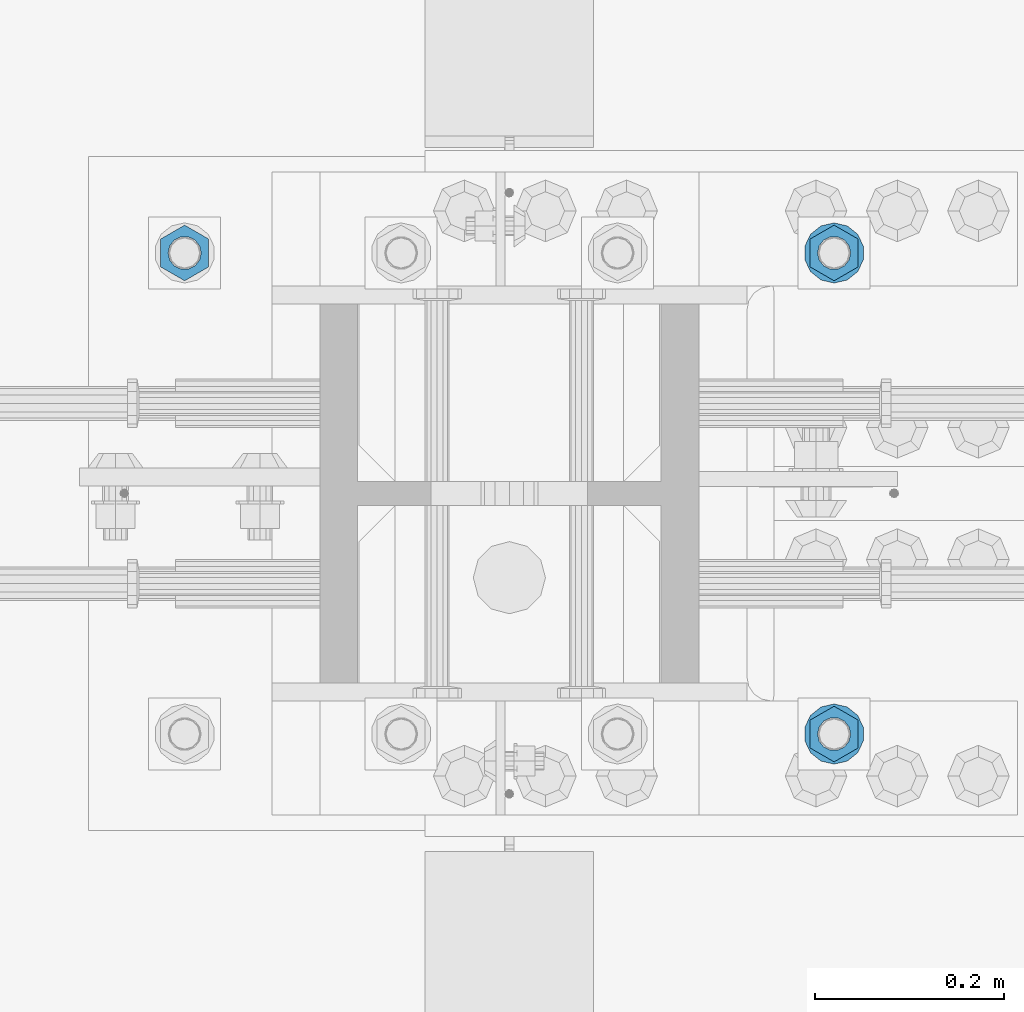
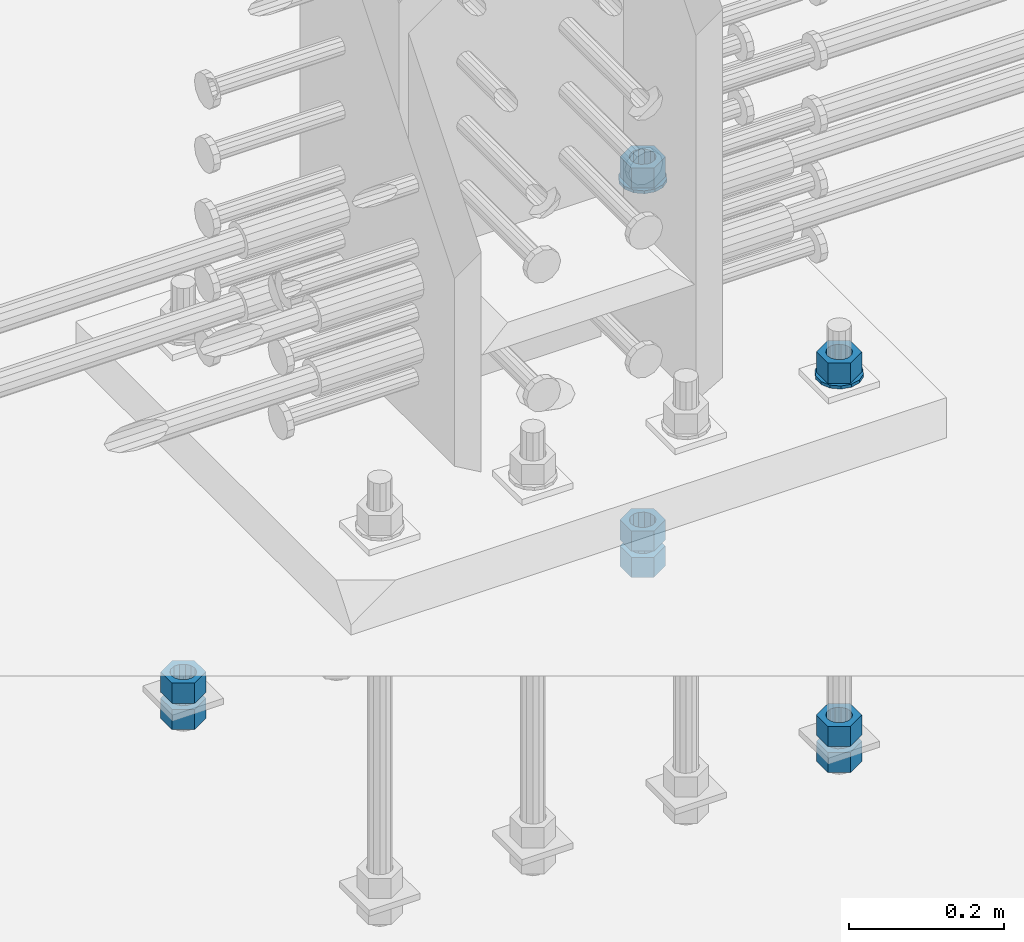
# One storey, part 993 of 1763: 10 columns, 1 element without a shape of its own.
"""IFC2X3 building model written with IfcOpenShell, lengths in millimetres."""

from ifc_helpers import new_model, si_unit, frame, origin_with_axes, place, context, subcontext, project, spatial, faceted_brep, material, type_object, element, aggregate, save


model = new_model("IFC2X3")

# Units and contexts
model_context = context("Model", 3, precision=1e-05, world=origin_with_axes())
body_context = subcontext(model_context, "Body", "Model", "MODEL_VIEW")
ifc_project = project(units=[si_unit("LENGTHUNIT", "METRE", prefix="MILLI"), si_unit("AREAUNIT", "SQUARE_METRE"), si_unit("VOLUMEUNIT", "CUBIC_METRE"), si_unit("MASSUNIT", "GRAM", prefix="KILO"), si_unit("TIMEUNIT", "SECOND"), si_unit("PLANEANGLEUNIT", "RADIAN"), si_unit("SOLIDANGLEUNIT", "STERADIAN"), si_unit("THERMODYNAMICTEMPERATUREUNIT", "DEGREE_CELSIUS"), si_unit("LUMINOUSINTENSITYUNIT", "LUMEN")], contexts=[model_context])

# Site, building, storey
site_placement = place(None, origin_with_axes())
site = spatial("IfcSite", under=ifc_project, at=site_placement, CompositionType="ELEMENT")
building_placement = place(site_placement, origin_with_axes())
building = spatial("IfcBuilding", under=site, at=building_placement, Name="Undefined", CompositionType="ELEMENT")
storey_placement = place(building_placement, origin_with_axes())
storey = spatial("IfcBuildingStorey", under=building, at=storey_placement, Name="Undefined", CompositionType="ELEMENT", Elevation=0.0)

# Assembly, columns
assembly_placement = place(storey_placement, origin_with_axes())
assembly = element("IfcElementAssembly", 1, at=assembly_placement, inside=storey, Name="TEMPLATE", AssemblyPlace="NOTDEFINED", PredefinedType="RIGID_FRAME")
ifc_material_1 = material(Name="STEEL/A563")
column_type_1 = type_object("IfcColumnType", Name="1-1/4_HEAVY_HEX_NUT", PredefinedType="NOTDEFINED")
column_1_placement = place(assembly_placement, frame((-72148.1372736972, 203.200000000843, 3957.6375), z_axis=(1.0, 0.0, 0.0), x_axis=(0.0, 0.0, -1.0)))
column_1 = element("IfcColumn", 2, at=column_1_placement, type_object=column_type_1, material=ifc_material_1, Name="NUT", ObjectType="1-1/4_HEAVY_HEX_NUT", context=body_context, shape_type="Brep", body=[
    faceted_brep([(0.0, -29.3700008392334, 0.0), (0.0, -14.6800003051758, -25.4300003051758), (31.75, -14.6800003051758, -25.4300003051758), (31.75, -29.3700008392334, 0.0), (0.0, 14.6800003051758, -25.4300003051758), (31.75, 14.6800003051758, -25.4300003051758), (0.0, 29.3700008392334, 0.0), (31.75, 29.3700008392334, 0.0), (0.0, 14.6800003051758, 25.4300003051758), (31.75, 14.6800003051758, 25.4300003051758), (0.0, -14.6800003051758, 25.4300003051758), (31.75, -14.6800003051758, 25.4300003051758), (0.0, 0.0, 17.4599990844727), (0.0, 7.57560968776022, 15.730915608714), (31.75, 7.57560968775942, 15.7309156087145), (31.75, 0.0, 17.4599990844727), (0.0, 13.6507769681037, 10.8861313696252), (31.75, 13.6507769681048, 10.8861313696314), (0.0, 17.0222404541215, 3.88521530314756), (31.75, 17.02224045412, 3.88521530315316), (0.0, 17.0222404541215, -3.88521530314756), (31.75, 17.02224045412, -3.88521530315332), (0.0, 13.6507769681037, -10.8861313696252), (31.75, 13.6507769681048, -10.8861313696316), (0.0, 7.57560968776022, -15.730915608714), (31.75, 7.57560968775942, -15.7309156087146), (0.0, 0.0, -17.4599990844727), (31.75, 0.0, -17.4599990844727), (0.0, -7.57560968776022, -15.730915608714), (31.75, -7.57560968775942, -15.7309156087145), (0.0, -13.6507769681037, -10.8861313696252), (31.75, -13.6507769681048, -10.8861313696314), (0.0, -17.0222404541215, -3.88521530314756), (31.75, -17.02224045412, -3.88521530315316), (0.0, -17.0222404541215, 3.88521530314756), (31.75, -17.02224045412, 3.88521530315332), (0.0, -13.6507769681037, 10.8861313696252), (31.75, -13.6507769681048, 10.8861313696316), (0.0, -7.57560968776022, 15.730915608714), (31.75, -7.57560968775942, 15.7309156087146)], [[[0, 1, 2, 3]], [[1, 4, 5, 2]], [[4, 6, 7, 5]], [[6, 8, 9, 7]], [[8, 10, 11, 9]], [[10, 0, 3, 11]], [[12, 13, 14, 15]], [[13, 16, 17, 14]], [[16, 18, 19, 17]], [[18, 20, 21, 19]], [[20, 22, 23, 21]], [[22, 24, 25, 23]], [[24, 26, 27, 25]], [[26, 28, 29, 27]], [[28, 30, 31, 29]], [[30, 32, 33, 31]], [[32, 34, 35, 33]], [[34, 36, 37, 35]], [[36, 38, 39, 37]], [[38, 12, 15, 39]], [[5, 7, 9, 11, 3, 2], [17, 19, 21, 23, 25, 27, 29, 31, 33, 35, 37, 39, 15, 14]], [[10, 8, 6, 4, 1, 0], [38, 36, 34, 32, 30, 28, 26, 24, 22, 20, 18, 16, 13, 12]]]),
])
column_2_placement = place(assembly_placement, frame((-72148.1372736972, 203.200000000843, 3384.55), z_axis=(1.0, 0.0, 0.0), x_axis=(0.0, 0.0, -1.0)))
column_2 = element("IfcColumn", 3, at=column_2_placement, type_object=column_type_1, material=ifc_material_1, Name="NUT", ObjectType="1-1/4_HEAVY_HEX_NUT", context=body_context, shape_type="Brep", body=[
    faceted_brep([(0.0, -29.3700008392334, 0.0), (0.0, -14.6800003051758, -25.4300003051758), (31.75, -14.6800003051758, -25.4300003051758), (31.75, -29.3700008392334, 0.0), (0.0, 14.6800003051758, -25.4300003051758), (31.75, 14.6800003051758, -25.4300003051758), (0.0, 29.3700008392334, 0.0), (31.75, 29.3700008392334, 0.0), (0.0, 14.6800003051758, 25.4300003051758), (31.75, 14.6800003051758, 25.4300003051758), (0.0, -14.6800003051758, 25.4300003051758), (31.75, -14.6800003051758, 25.4300003051758), (0.0, 0.0, 17.4599990844727), (0.0, 7.57560968776022, 15.730915608714), (31.75, 7.57560968775942, 15.7309156087145), (31.75, 0.0, 17.4599990844727), (0.0, 13.6507769681037, 10.8861313696252), (31.75, 13.6507769681048, 10.8861313696314), (0.0, 17.0222404541215, 3.88521530314756), (31.75, 17.02224045412, 3.88521530315316), (0.0, 17.0222404541215, -3.88521530314756), (31.75, 17.02224045412, -3.88521530315332), (0.0, 13.6507769681037, -10.8861313696252), (31.75, 13.6507769681048, -10.8861313696316), (0.0, 7.57560968776022, -15.730915608714), (31.75, 7.57560968775942, -15.7309156087146), (0.0, 0.0, -17.4599990844727), (31.75, 0.0, -17.4599990844727), (0.0, -7.57560968776022, -15.730915608714), (31.75, -7.57560968775942, -15.7309156087145), (0.0, -13.6507769681037, -10.8861313696252), (31.75, -13.6507769681048, -10.8861313696314), (0.0, -17.0222404541215, -3.88521530314756), (31.75, -17.02224045412, -3.88521530315316), (0.0, -17.0222404541215, 3.88521530314756), (31.75, -17.02224045412, 3.88521530315332), (0.0, -13.6507769681037, 10.8861313696252), (31.75, -13.6507769681048, 10.8861313696316), (0.0, -7.57560968776022, 15.730915608714), (31.75, -7.57560968775942, 15.7309156087146)], [[[0, 1, 2, 3]], [[1, 4, 5, 2]], [[4, 6, 7, 5]], [[6, 8, 9, 7]], [[8, 10, 11, 9]], [[10, 0, 3, 11]], [[12, 13, 14, 15]], [[13, 16, 17, 14]], [[16, 18, 19, 17]], [[18, 20, 21, 19]], [[20, 22, 23, 21]], [[22, 24, 25, 23]], [[24, 26, 27, 25]], [[26, 28, 29, 27]], [[28, 30, 31, 29]], [[30, 32, 33, 31]], [[32, 34, 35, 33]], [[34, 36, 37, 35]], [[36, 38, 39, 37]], [[38, 12, 15, 39]], [[5, 7, 9, 11, 3, 2], [17, 19, 21, 23, 25, 27, 29, 31, 33, 35, 37, 39, 15, 14]], [[10, 8, 6, 4, 1, 0], [38, 36, 34, 32, 30, 28, 26, 24, 22, 20, 18, 16, 13, 12]]]),
])
column_3_placement = place(assembly_placement, frame((-72148.1372736972, 203.200000000843, 3343.275), z_axis=(1.0, 0.0, 0.0), x_axis=(0.0, 0.0, -1.0)))
column_3 = element("IfcColumn", 4, at=column_3_placement, type_object=column_type_1, material=ifc_material_1, Name="NUT", ObjectType="1-1/4_HEAVY_HEX_NUT", context=body_context, shape_type="Brep", body=[
    faceted_brep([(0.0, -29.3700008392334, 0.0), (0.0, -14.6800003051758, -25.4300003051758), (31.75, -14.6800003051758, -25.4300003051758), (31.75, -29.3700008392334, 0.0), (0.0, 14.6800003051758, -25.4300003051758), (31.75, 14.6800003051758, -25.4300003051758), (0.0, 29.3700008392334, 0.0), (31.75, 29.3700008392334, 0.0), (0.0, 14.6800003051758, 25.4300003051758), (31.75, 14.6800003051758, 25.4300003051758), (0.0, -14.6800003051758, 25.4300003051758), (31.75, -14.6800003051758, 25.4300003051758), (0.0, 0.0, 17.4599990844727), (0.0, 7.57560968776022, 15.730915608714), (31.75, 7.57560968775942, 15.7309156087145), (31.75, 0.0, 17.4599990844727), (0.0, 13.6507769681037, 10.8861313696252), (31.75, 13.6507769681048, 10.8861313696314), (0.0, 17.0222404541215, 3.88521530314756), (31.75, 17.02224045412, 3.88521530315316), (0.0, 17.0222404541215, -3.88521530314756), (31.75, 17.02224045412, -3.88521530315332), (0.0, 13.6507769681037, -10.8861313696252), (31.75, 13.6507769681048, -10.8861313696316), (0.0, 7.57560968776022, -15.730915608714), (31.75, 7.57560968775942, -15.7309156087146), (0.0, 0.0, -17.4599990844727), (31.75, 0.0, -17.4599990844727), (0.0, -7.57560968776022, -15.730915608714), (31.75, -7.57560968775942, -15.7309156087145), (0.0, -13.6507769681037, -10.8861313696252), (31.75, -13.6507769681048, -10.8861313696314), (0.0, -17.0222404541215, -3.88521530314756), (31.75, -17.02224045412, -3.88521530315316), (0.0, -17.0222404541215, 3.88521530314756), (31.75, -17.02224045412, 3.88521530315332), (0.0, -13.6507769681037, 10.8861313696252), (31.75, -13.6507769681048, 10.8861313696316), (0.0, -7.57560968776022, 15.730915608714), (31.75, -7.57560968775942, 15.7309156087146)], [[[0, 1, 2, 3]], [[1, 4, 5, 2]], [[4, 6, 7, 5]], [[6, 8, 9, 7]], [[8, 10, 11, 9]], [[10, 0, 3, 11]], [[12, 13, 14, 15]], [[13, 16, 17, 14]], [[16, 18, 19, 17]], [[18, 20, 21, 19]], [[20, 22, 23, 21]], [[22, 24, 25, 23]], [[24, 26, 27, 25]], [[26, 28, 29, 27]], [[28, 30, 31, 29]], [[30, 32, 33, 31]], [[32, 34, 35, 33]], [[34, 36, 37, 35]], [[36, 38, 39, 37]], [[38, 12, 15, 39]], [[5, 7, 9, 11, 3, 2], [17, 19, 21, 23, 25, 27, 29, 31, 33, 35, 37, 39, 15, 14]], [[10, 8, 6, 4, 1, 0], [38, 36, 34, 32, 30, 28, 26, 24, 22, 20, 18, 16, 13, 12]]]),
])
column_4_placement = place(assembly_placement, frame((-72148.1372736972, 711.200000000843, 3957.6375), z_axis=(-1.0, 0.0, 0.0), x_axis=(0.0, 0.0, -1.0)))
column_4 = element("IfcColumn", 5, at=column_4_placement, type_object=column_type_1, material=ifc_material_1, Name="NUT", ObjectType="1-1/4_HEAVY_HEX_NUT", context=body_context, shape_type="Brep", body=[
    faceted_brep([(0.0, -29.3700008392334, 0.0), (0.0, -14.6800003051758, -25.4300003051758), (31.75, -14.6800003051758, -25.4300003051758), (31.75, -29.3700008392334, 0.0), (0.0, 14.6800003051758, -25.4300003051758), (31.75, 14.6800003051758, -25.4300003051758), (0.0, 29.3700008392334, 0.0), (31.75, 29.3700008392334, 0.0), (0.0, 14.6800003051758, 25.4300003051758), (31.75, 14.6800003051758, 25.4300003051758), (0.0, -14.6800003051758, 25.4300003051758), (31.75, -14.6800003051758, 25.4300003051758), (0.0, 0.0, 17.4599990844727), (0.0, 7.57560968776022, 15.730915608714), (31.75, 7.57560968775942, 15.7309156087145), (31.75, 0.0, 17.4599990844727), (0.0, 13.6507769681037, 10.8861313696252), (31.75, 13.6507769681048, 10.8861313696314), (0.0, 17.0222404541215, 3.88521530314756), (31.75, 17.02224045412, 3.88521530315316), (0.0, 17.0222404541215, -3.88521530314756), (31.75, 17.02224045412, -3.88521530315332), (0.0, 13.6507769681037, -10.8861313696252), (31.75, 13.6507769681048, -10.8861313696316), (0.0, 7.57560968776022, -15.730915608714), (31.75, 7.57560968775942, -15.7309156087146), (0.0, 0.0, -17.4599990844727), (31.75, 0.0, -17.4599990844727), (0.0, -7.57560968776022, -15.730915608714), (31.75, -7.57560968775942, -15.7309156087145), (0.0, -13.6507769681037, -10.8861313696252), (31.75, -13.6507769681048, -10.8861313696314), (0.0, -17.0222404541215, -3.88521530314756), (31.75, -17.02224045412, -3.88521530315316), (0.0, -17.0222404541215, 3.88521530314756), (31.75, -17.02224045412, 3.88521530315332), (0.0, -13.6507769681037, 10.8861313696252), (31.75, -13.6507769681048, 10.8861313696316), (0.0, -7.57560968776022, 15.730915608714), (31.75, -7.57560968775942, 15.7309156087146)], [[[0, 1, 2, 3]], [[1, 4, 5, 2]], [[4, 6, 7, 5]], [[6, 8, 9, 7]], [[8, 10, 11, 9]], [[10, 0, 3, 11]], [[12, 13, 14, 15]], [[13, 16, 17, 14]], [[16, 18, 19, 17]], [[18, 20, 21, 19]], [[20, 22, 23, 21]], [[22, 24, 25, 23]], [[24, 26, 27, 25]], [[26, 28, 29, 27]], [[28, 30, 31, 29]], [[30, 32, 33, 31]], [[32, 34, 35, 33]], [[34, 36, 37, 35]], [[36, 38, 39, 37]], [[38, 12, 15, 39]], [[5, 7, 9, 11, 3, 2], [17, 19, 21, 23, 25, 27, 29, 31, 33, 35, 37, 39, 15, 14]], [[10, 8, 6, 4, 1, 0], [38, 36, 34, 32, 30, 28, 26, 24, 22, 20, 18, 16, 13, 12]]]),
])
column_5_placement = place(assembly_placement, frame((-72148.1372736972, 711.200000000843, 3384.55), z_axis=(-1.0, 0.0, 0.0), x_axis=(0.0, 0.0, -1.0)))
column_5 = element("IfcColumn", 6, at=column_5_placement, type_object=column_type_1, material=ifc_material_1, Name="NUT", ObjectType="1-1/4_HEAVY_HEX_NUT", context=body_context, shape_type="Brep", body=[
    faceted_brep([(0.0, -29.3700008392334, 0.0), (0.0, -14.6800003051758, -25.4300003051758), (31.75, -14.6800003051758, -25.4300003051758), (31.75, -29.3700008392334, 0.0), (0.0, 14.6800003051758, -25.4300003051758), (31.75, 14.6800003051758, -25.4300003051758), (0.0, 29.3700008392334, 0.0), (31.75, 29.3700008392334, 0.0), (0.0, 14.6800003051758, 25.4300003051758), (31.75, 14.6800003051758, 25.4300003051758), (0.0, -14.6800003051758, 25.4300003051758), (31.75, -14.6800003051758, 25.4300003051758), (0.0, 0.0, 17.4599990844727), (0.0, 7.57560968776022, 15.730915608714), (31.75, 7.57560968775942, 15.7309156087145), (31.75, 0.0, 17.4599990844727), (0.0, 13.6507769681037, 10.8861313696252), (31.75, 13.6507769681048, 10.8861313696314), (0.0, 17.0222404541215, 3.88521530314756), (31.75, 17.02224045412, 3.88521530315316), (0.0, 17.0222404541215, -3.88521530314756), (31.75, 17.02224045412, -3.88521530315332), (0.0, 13.6507769681037, -10.8861313696252), (31.75, 13.6507769681048, -10.8861313696316), (0.0, 7.57560968776022, -15.730915608714), (31.75, 7.57560968775942, -15.7309156087146), (0.0, 0.0, -17.4599990844727), (31.75, 0.0, -17.4599990844727), (0.0, -7.57560968776022, -15.730915608714), (31.75, -7.57560968775942, -15.7309156087145), (0.0, -13.6507769681037, -10.8861313696252), (31.75, -13.6507769681048, -10.8861313696314), (0.0, -17.0222404541215, -3.88521530314756), (31.75, -17.02224045412, -3.88521530315316), (0.0, -17.0222404541215, 3.88521530314756), (31.75, -17.02224045412, 3.88521530315332), (0.0, -13.6507769681037, 10.8861313696252), (31.75, -13.6507769681048, 10.8861313696316), (0.0, -7.57560968776022, 15.730915608714), (31.75, -7.57560968775942, 15.7309156087146)], [[[0, 1, 2, 3]], [[1, 4, 5, 2]], [[4, 6, 7, 5]], [[6, 8, 9, 7]], [[8, 10, 11, 9]], [[10, 0, 3, 11]], [[12, 13, 14, 15]], [[13, 16, 17, 14]], [[16, 18, 19, 17]], [[18, 20, 21, 19]], [[20, 22, 23, 21]], [[22, 24, 25, 23]], [[24, 26, 27, 25]], [[26, 28, 29, 27]], [[28, 30, 31, 29]], [[30, 32, 33, 31]], [[32, 34, 35, 33]], [[34, 36, 37, 35]], [[36, 38, 39, 37]], [[38, 12, 15, 39]], [[5, 7, 9, 11, 3, 2], [17, 19, 21, 23, 25, 27, 29, 31, 33, 35, 37, 39, 15, 14]], [[10, 8, 6, 4, 1, 0], [38, 36, 34, 32, 30, 28, 26, 24, 22, 20, 18, 16, 13, 12]]]),
])
column_6_placement = place(assembly_placement, frame((-72148.1372736972, 711.200000000843, 3343.275), z_axis=(-1.0, 0.0, 0.0), x_axis=(0.0, 0.0, -1.0)))
column_6 = element("IfcColumn", 7, at=column_6_placement, type_object=column_type_1, material=ifc_material_1, Name="NUT", ObjectType="1-1/4_HEAVY_HEX_NUT", context=body_context, shape_type="Brep", body=[
    faceted_brep([(0.0, -29.3700008392334, 0.0), (0.0, -14.6800003051758, -25.4300003051758), (31.75, -14.6800003051758, -25.4300003051758), (31.75, -29.3700008392334, 0.0), (0.0, 14.6800003051758, -25.4300003051758), (31.75, 14.6800003051758, -25.4300003051758), (0.0, 29.3700008392334, 0.0), (31.75, 29.3700008392334, 0.0), (0.0, 14.6800003051758, 25.4300003051758), (31.75, 14.6800003051758, 25.4300003051758), (0.0, -14.6800003051758, 25.4300003051758), (31.75, -14.6800003051758, 25.4300003051758), (0.0, 0.0, 17.4599990844727), (0.0, 7.57560968776022, 15.730915608714), (31.75, 7.57560968775942, 15.7309156087145), (31.75, 0.0, 17.4599990844727), (0.0, 13.6507769681037, 10.8861313696252), (31.75, 13.6507769681048, 10.8861313696314), (0.0, 17.0222404541215, 3.88521530314756), (31.75, 17.02224045412, 3.88521530315316), (0.0, 17.0222404541215, -3.88521530314756), (31.75, 17.02224045412, -3.88521530315332), (0.0, 13.6507769681037, -10.8861313696252), (31.75, 13.6507769681048, -10.8861313696316), (0.0, 7.57560968776022, -15.730915608714), (31.75, 7.57560968775942, -15.7309156087146), (0.0, 0.0, -17.4599990844727), (31.75, 0.0, -17.4599990844727), (0.0, -7.57560968776022, -15.730915608714), (31.75, -7.57560968775942, -15.7309156087145), (0.0, -13.6507769681037, -10.8861313696252), (31.75, -13.6507769681048, -10.8861313696314), (0.0, -17.0222404541215, -3.88521530314756), (31.75, -17.02224045412, -3.88521530315316), (0.0, -17.0222404541215, 3.88521530314756), (31.75, -17.02224045412, 3.88521530315332), (0.0, -13.6507769681037, 10.8861313696252), (31.75, -13.6507769681048, 10.8861313696316), (0.0, -7.57560968776022, 15.730915608714), (31.75, -7.57560968775942, 15.7309156087146)], [[[0, 1, 2, 3]], [[1, 4, 5, 2]], [[4, 6, 7, 5]], [[6, 8, 9, 7]], [[8, 10, 11, 9]], [[10, 0, 3, 11]], [[12, 13, 14, 15]], [[13, 16, 17, 14]], [[16, 18, 19, 17]], [[18, 20, 21, 19]], [[20, 22, 23, 21]], [[22, 24, 25, 23]], [[24, 26, 27, 25]], [[26, 28, 29, 27]], [[28, 30, 31, 29]], [[30, 32, 33, 31]], [[32, 34, 35, 33]], [[34, 36, 37, 35]], [[36, 38, 39, 37]], [[38, 12, 15, 39]], [[5, 7, 9, 11, 3, 2], [17, 19, 21, 23, 25, 27, 29, 31, 33, 35, 37, 39, 15, 14]], [[10, 8, 6, 4, 1, 0], [38, 36, 34, 32, 30, 28, 26, 24, 22, 20, 18, 16, 13, 12]]]),
])
column_7_placement = place(assembly_placement, frame((-72833.9372736972, 711.200000000843, 3384.55), z_axis=(-1.0, 0.0, 0.0), x_axis=(0.0, 0.0, -1.0)))
column_7 = element("IfcColumn", 8, at=column_7_placement, type_object=column_type_1, material=ifc_material_1, Name="NUT", ObjectType="1-1/4_HEAVY_HEX_NUT", context=body_context, shape_type="Brep", body=[
    faceted_brep([(0.0, -29.3700008392334, 0.0), (0.0, -14.6800003051758, -25.4300003051758), (31.75, -14.6800003051758, -25.4300003051758), (31.75, -29.3700008392334, 0.0), (0.0, 14.6800003051758, -25.4300003051758), (31.75, 14.6800003051758, -25.4300003051758), (0.0, 29.3700008392334, 0.0), (31.75, 29.3700008392334, 0.0), (0.0, 14.6800003051758, 25.4300003051758), (31.75, 14.6800003051758, 25.4300003051758), (0.0, -14.6800003051758, 25.4300003051758), (31.75, -14.6800003051758, 25.4300003051758), (0.0, 0.0, 17.4599990844727), (0.0, 7.57560968776022, 15.730915608714), (31.75, 7.57560968775942, 15.7309156087145), (31.75, 0.0, 17.4599990844727), (0.0, 13.6507769681037, 10.8861313696252), (31.75, 13.6507769681048, 10.8861313696314), (0.0, 17.0222404541215, 3.88521530314756), (31.75, 17.02224045412, 3.88521530315316), (0.0, 17.0222404541215, -3.88521530314756), (31.75, 17.02224045412, -3.88521530315332), (0.0, 13.6507769681037, -10.8861313696252), (31.75, 13.6507769681048, -10.8861313696316), (0.0, 7.57560968776022, -15.730915608714), (31.75, 7.57560968775942, -15.7309156087146), (0.0, 0.0, -17.4599990844727), (31.75, 0.0, -17.4599990844727), (0.0, -7.57560968776022, -15.730915608714), (31.75, -7.57560968775942, -15.7309156087145), (0.0, -13.6507769681037, -10.8861313696252), (31.75, -13.6507769681048, -10.8861313696314), (0.0, -17.0222404541215, -3.88521530314756), (31.75, -17.02224045412, -3.88521530315316), (0.0, -17.0222404541215, 3.88521530314756), (31.75, -17.02224045412, 3.88521530315332), (0.0, -13.6507769681037, 10.8861313696252), (31.75, -13.6507769681048, 10.8861313696316), (0.0, -7.57560968776022, 15.730915608714), (31.75, -7.57560968775942, 15.7309156087146)], [[[0, 1, 2, 3]], [[1, 4, 5, 2]], [[4, 6, 7, 5]], [[6, 8, 9, 7]], [[8, 10, 11, 9]], [[10, 0, 3, 11]], [[12, 13, 14, 15]], [[13, 16, 17, 14]], [[16, 18, 19, 17]], [[18, 20, 21, 19]], [[20, 22, 23, 21]], [[22, 24, 25, 23]], [[24, 26, 27, 25]], [[26, 28, 29, 27]], [[28, 30, 31, 29]], [[30, 32, 33, 31]], [[32, 34, 35, 33]], [[34, 36, 37, 35]], [[36, 38, 39, 37]], [[38, 12, 15, 39]], [[5, 7, 9, 11, 3, 2], [17, 19, 21, 23, 25, 27, 29, 31, 33, 35, 37, 39, 15, 14]], [[10, 8, 6, 4, 1, 0], [38, 36, 34, 32, 30, 28, 26, 24, 22, 20, 18, 16, 13, 12]]]),
])
column_8_placement = place(assembly_placement, frame((-72833.9372736972, 711.200000000843, 3343.275), z_axis=(-1.0, 0.0, 0.0), x_axis=(0.0, 0.0, -1.0)))
column_8 = element("IfcColumn", 9, at=column_8_placement, type_object=column_type_1, material=ifc_material_1, Name="NUT", ObjectType="1-1/4_HEAVY_HEX_NUT", context=body_context, shape_type="Brep", body=[
    faceted_brep([(0.0, -29.3700008392334, 0.0), (0.0, -14.6800003051758, -25.4300003051758), (31.75, -14.6800003051758, -25.4300003051758), (31.75, -29.3700008392334, 0.0), (0.0, 14.6800003051758, -25.4300003051758), (31.75, 14.6800003051758, -25.4300003051758), (0.0, 29.3700008392334, 0.0), (31.75, 29.3700008392334, 0.0), (0.0, 14.6800003051758, 25.4300003051758), (31.75, 14.6800003051758, 25.4300003051758), (0.0, -14.6800003051758, 25.4300003051758), (31.75, -14.6800003051758, 25.4300003051758), (0.0, 0.0, 17.4599990844727), (0.0, 7.57560968776022, 15.730915608714), (31.75, 7.57560968775942, 15.7309156087145), (31.75, 0.0, 17.4599990844727), (0.0, 13.6507769681037, 10.8861313696252), (31.75, 13.6507769681048, 10.8861313696314), (0.0, 17.0222404541215, 3.88521530314756), (31.75, 17.02224045412, 3.88521530315316), (0.0, 17.0222404541215, -3.88521530314756), (31.75, 17.02224045412, -3.88521530315332), (0.0, 13.6507769681037, -10.8861313696252), (31.75, 13.6507769681048, -10.8861313696316), (0.0, 7.57560968776022, -15.730915608714), (31.75, 7.57560968775942, -15.7309156087146), (0.0, 0.0, -17.4599990844727), (31.75, 0.0, -17.4599990844727), (0.0, -7.57560968776022, -15.730915608714), (31.75, -7.57560968775942, -15.7309156087145), (0.0, -13.6507769681037, -10.8861313696252), (31.75, -13.6507769681048, -10.8861313696314), (0.0, -17.0222404541215, -3.88521530314756), (31.75, -17.02224045412, -3.88521530315316), (0.0, -17.0222404541215, 3.88521530314756), (31.75, -17.02224045412, 3.88521530315332), (0.0, -13.6507769681037, 10.8861313696252), (31.75, -13.6507769681048, 10.8861313696316), (0.0, -7.57560968776022, 15.730915608714), (31.75, -7.57560968775942, 15.7309156087146)], [[[0, 1, 2, 3]], [[1, 4, 5, 2]], [[4, 6, 7, 5]], [[6, 8, 9, 7]], [[8, 10, 11, 9]], [[10, 0, 3, 11]], [[12, 13, 14, 15]], [[13, 16, 17, 14]], [[16, 18, 19, 17]], [[18, 20, 21, 19]], [[20, 22, 23, 21]], [[22, 24, 25, 23]], [[24, 26, 27, 25]], [[26, 28, 29, 27]], [[28, 30, 31, 29]], [[30, 32, 33, 31]], [[32, 34, 35, 33]], [[34, 36, 37, 35]], [[36, 38, 39, 37]], [[38, 12, 15, 39]], [[5, 7, 9, 11, 3, 2], [17, 19, 21, 23, 25, 27, 29, 31, 33, 35, 37, 39, 15, 14]], [[10, 8, 6, 4, 1, 0], [38, 36, 34, 32, 30, 28, 26, 24, 22, 20, 18, 16, 13, 12]]]),
])
ifc_material_2 = material(Name="STEEL/F436")
column_type_2 = type_object("IfcColumnType", Name="1-1/4_WASHER", PredefinedType="NOTDEFINED")
column_9_placement = place(assembly_placement, frame((-72148.1372736972, 203.200000000843, 3925.8875), z_axis=(1.0, 0.0, 0.0), x_axis=(0.0, 0.0, -1.0)))
column_9 = element("IfcColumn", 10, at=column_9_placement, type_object=column_type_2, material=ifc_material_2, Name="WASHER", ObjectType="1-1/4_WASHER", context=body_context, shape_type="Brep", body=[
    faceted_brep([(-4.54747350886464e-13, -31.7499999999964, 0.0), (0.0, -28.6057615559002, -13.7758087169827), (4.76249999999982, -28.6057615559002, -13.7758087169827), (4.76249999999982, -31.75, 0.0), (0.0, -19.795801209013, -24.8231495683602), (4.76249999999982, -19.795801209013, -24.8231495683602), (0.0, -7.06503965311276, -30.9539612117732), (4.76249999999982, -7.06503965311276, -30.9539612117732), (0.0, 7.06503965311276, -30.9539612117732), (4.76249999999982, 7.06503965311276, -30.9539612117732), (0.0, 19.7958012090166, -24.8231495683602), (4.76249999999982, 19.7958012090166, -24.8231495683602), (0.0, 28.6057615559039, -13.7758087169827), (4.76249999999982, 28.6057615559039, -13.7758087169827), (-5.91171556152403e-12, 31.7499999999891, 0.0), (4.76249999999982, 31.75, 0.0), (0.0, 28.6057615559002, 13.7758087169827), (4.76249999999982, 28.6057615559002, 13.7758087169827), (0.0, 19.795801209013, 24.8231495683602), (4.76249999999982, 19.795801209013, 24.8231495683602), (0.0, 7.06503965311276, 30.9539612117731), (4.76249999999982, 7.06503965311276, 30.9539612117731), (0.0, -7.06503965311276, 30.9539612117731), (4.76249999999982, -7.06503965311276, 30.9539612117731), (0.0, -19.7958012090166, 24.8231495683602), (4.76249999999982, -19.7958012090166, 24.8231495683602), (0.0, -28.6057615559039, 13.7758087169827), (4.76249999999982, -28.6057615559039, 13.7758087169827), (0.0, 0.0, 17.4599990844727), (0.0, 7.57560968776022, 15.730915608714), (4.76249999999982, 7.57560968775942, 15.7309156087145), (4.76249999999982, 0.0, 17.4599990844727), (0.0, 13.6507769681037, 10.8861313696252), (4.76249999999982, 13.6507769681048, 10.8861313696314), (0.0, 17.0222404541215, 3.88521530314756), (4.76249999999982, 17.02224045412, 3.88521530315316), (0.0, 17.0222404541215, -3.88521530314756), (4.76249999999982, 17.02224045412, -3.88521530315332), (0.0, 13.6507769681037, -10.8861313696252), (4.76249999999982, 13.6507769681048, -10.8861313696316), (0.0, 7.57560968776022, -15.730915608714), (4.76249999999982, 7.57560968775942, -15.7309156087146), (0.0, 0.0, -17.4599990844727), (4.76249999999982, 0.0, -17.4599990844727), (0.0, -7.57560968776022, -15.730915608714), (4.76249999999982, -7.57560968775942, -15.7309156087145), (0.0, -13.6507769681037, -10.8861313696252), (4.76249999999982, -13.6507769681048, -10.8861313696314), (0.0, -17.0222404541215, -3.88521530314756), (4.76249999999982, -17.02224045412, -3.88521530315316), (0.0, -17.0222404541215, 3.88521530314756), (4.76249999999982, -17.02224045412, 3.88521530315332), (0.0, -13.6507769681037, 10.8861313696252), (4.76249999999982, -13.6507769681048, 10.8861313696316), (0.0, -7.57560968776022, 15.730915608714), (4.76249999999982, -7.57560968775942, 15.7309156087146)], [[[0, 1, 2, 3]], [[1, 4, 5, 2]], [[4, 6, 7, 5]], [[6, 8, 9, 7]], [[8, 10, 11, 9]], [[10, 12, 13, 11]], [[12, 14, 15, 13]], [[14, 16, 17, 15]], [[16, 18, 19, 17]], [[18, 20, 21, 19]], [[20, 22, 23, 21]], [[22, 24, 25, 23]], [[24, 26, 27, 25]], [[26, 0, 3, 27]], [[28, 29, 30, 31]], [[29, 32, 33, 30]], [[32, 34, 35, 33]], [[34, 36, 37, 35]], [[36, 38, 39, 37]], [[38, 40, 41, 39]], [[40, 42, 43, 41]], [[42, 44, 45, 43]], [[44, 46, 47, 45]], [[46, 48, 49, 47]], [[48, 50, 51, 49]], [[50, 52, 53, 51]], [[52, 54, 55, 53]], [[54, 28, 31, 55]], [[5, 7, 9, 11, 13, 15, 17, 19, 21, 23, 25, 27, 3, 2], [33, 35, 37, 39, 41, 43, 45, 47, 49, 51, 53, 55, 31, 30]], [[26, 24, 22, 20, 18, 16, 14, 12, 10, 8, 6, 4, 1, 0], [54, 52, 50, 48, 46, 44, 42, 40, 38, 36, 34, 32, 29, 28]]]),
])
column_10_placement = place(assembly_placement, frame((-72148.1372736972, 711.200000000843, 3925.8875), z_axis=(-1.0, 0.0, 0.0), x_axis=(0.0, 0.0, -1.0)))
column_10 = element("IfcColumn", 11, at=column_10_placement, type_object=column_type_2, material=ifc_material_2, Name="WASHER", ObjectType="1-1/4_WASHER", context=body_context, shape_type="Brep", body=[
    faceted_brep([(-4.54747350886464e-13, -31.7499999999964, 0.0), (0.0, -28.6057615559002, -13.7758087169827), (4.76249999999982, -28.6057615559002, -13.7758087169827), (4.76249999999982, -31.75, 0.0), (0.0, -19.795801209013, -24.8231495683602), (4.76249999999982, -19.795801209013, -24.8231495683602), (0.0, -7.06503965311276, -30.9539612117732), (4.76249999999982, -7.06503965311276, -30.9539612117732), (0.0, 7.06503965311276, -30.9539612117732), (4.76249999999982, 7.06503965311276, -30.9539612117732), (0.0, 19.7958012090166, -24.8231495683602), (4.76249999999982, 19.7958012090166, -24.8231495683602), (0.0, 28.6057615559039, -13.7758087169827), (4.76249999999982, 28.6057615559039, -13.7758087169827), (-5.91171556152403e-12, 31.7499999999891, 0.0), (4.76249999999982, 31.75, 0.0), (0.0, 28.6057615559002, 13.7758087169827), (4.76249999999982, 28.6057615559002, 13.7758087169827), (0.0, 19.795801209013, 24.8231495683602), (4.76249999999982, 19.795801209013, 24.8231495683602), (0.0, 7.06503965311276, 30.9539612117731), (4.76249999999982, 7.06503965311276, 30.9539612117731), (0.0, -7.06503965311276, 30.9539612117731), (4.76249999999982, -7.06503965311276, 30.9539612117731), (0.0, -19.7958012090166, 24.8231495683602), (4.76249999999982, -19.7958012090166, 24.8231495683602), (0.0, -28.6057615559039, 13.7758087169827), (4.76249999999982, -28.6057615559039, 13.7758087169827), (0.0, 0.0, 17.4599990844727), (0.0, 7.57560968776022, 15.730915608714), (4.76249999999982, 7.57560968775942, 15.7309156087145), (4.76249999999982, 0.0, 17.4599990844727), (0.0, 13.6507769681037, 10.8861313696252), (4.76249999999982, 13.6507769681048, 10.8861313696314), (0.0, 17.0222404541215, 3.88521530314756), (4.76249999999982, 17.02224045412, 3.88521530315316), (0.0, 17.0222404541215, -3.88521530314756), (4.76249999999982, 17.02224045412, -3.88521530315332), (0.0, 13.6507769681037, -10.8861313696252), (4.76249999999982, 13.6507769681048, -10.8861313696316), (0.0, 7.57560968776022, -15.730915608714), (4.76249999999982, 7.57560968775942, -15.7309156087146), (0.0, 0.0, -17.4599990844727), (4.76249999999982, 0.0, -17.4599990844727), (0.0, -7.57560968776022, -15.730915608714), (4.76249999999982, -7.57560968775942, -15.7309156087145), (0.0, -13.6507769681037, -10.8861313696252), (4.76249999999982, -13.6507769681048, -10.8861313696314), (0.0, -17.0222404541215, -3.88521530314756), (4.76249999999982, -17.02224045412, -3.88521530315316), (0.0, -17.0222404541215, 3.88521530314756), (4.76249999999982, -17.02224045412, 3.88521530315332), (0.0, -13.6507769681037, 10.8861313696252), (4.76249999999982, -13.6507769681048, 10.8861313696316), (0.0, -7.57560968776022, 15.730915608714), (4.76249999999982, -7.57560968775942, 15.7309156087146)], [[[0, 1, 2, 3]], [[1, 4, 5, 2]], [[4, 6, 7, 5]], [[6, 8, 9, 7]], [[8, 10, 11, 9]], [[10, 12, 13, 11]], [[12, 14, 15, 13]], [[14, 16, 17, 15]], [[16, 18, 19, 17]], [[18, 20, 21, 19]], [[20, 22, 23, 21]], [[22, 24, 25, 23]], [[24, 26, 27, 25]], [[26, 0, 3, 27]], [[28, 29, 30, 31]], [[29, 32, 33, 30]], [[32, 34, 35, 33]], [[34, 36, 37, 35]], [[36, 38, 39, 37]], [[38, 40, 41, 39]], [[40, 42, 43, 41]], [[42, 44, 45, 43]], [[44, 46, 47, 45]], [[46, 48, 49, 47]], [[48, 50, 51, 49]], [[50, 52, 53, 51]], [[52, 54, 55, 53]], [[54, 28, 31, 55]], [[5, 7, 9, 11, 13, 15, 17, 19, 21, 23, 25, 27, 3, 2], [33, 35, 37, 39, 41, 43, 45, 47, 49, 51, 53, 55, 31, 30]], [[26, 24, 22, 20, 18, 16, 14, 12, 10, 8, 6, 4, 1, 0], [54, 52, 50, 48, 46, 44, 42, 40, 38, 36, 34, 32, 29, 28]]]),
])
aggregate(assembly, [column_1, column_9, column_2, column_3, column_4, column_10, column_5, column_6, column_7, column_8])

save(model, "model.ifc")
